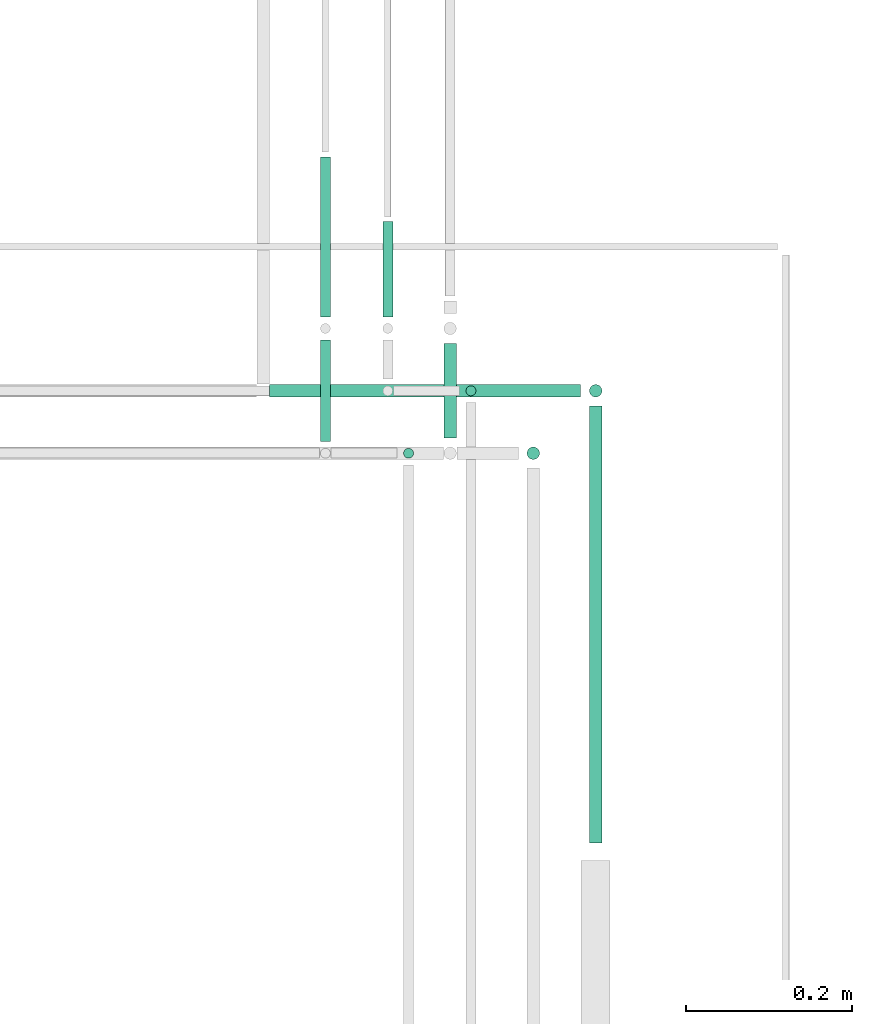
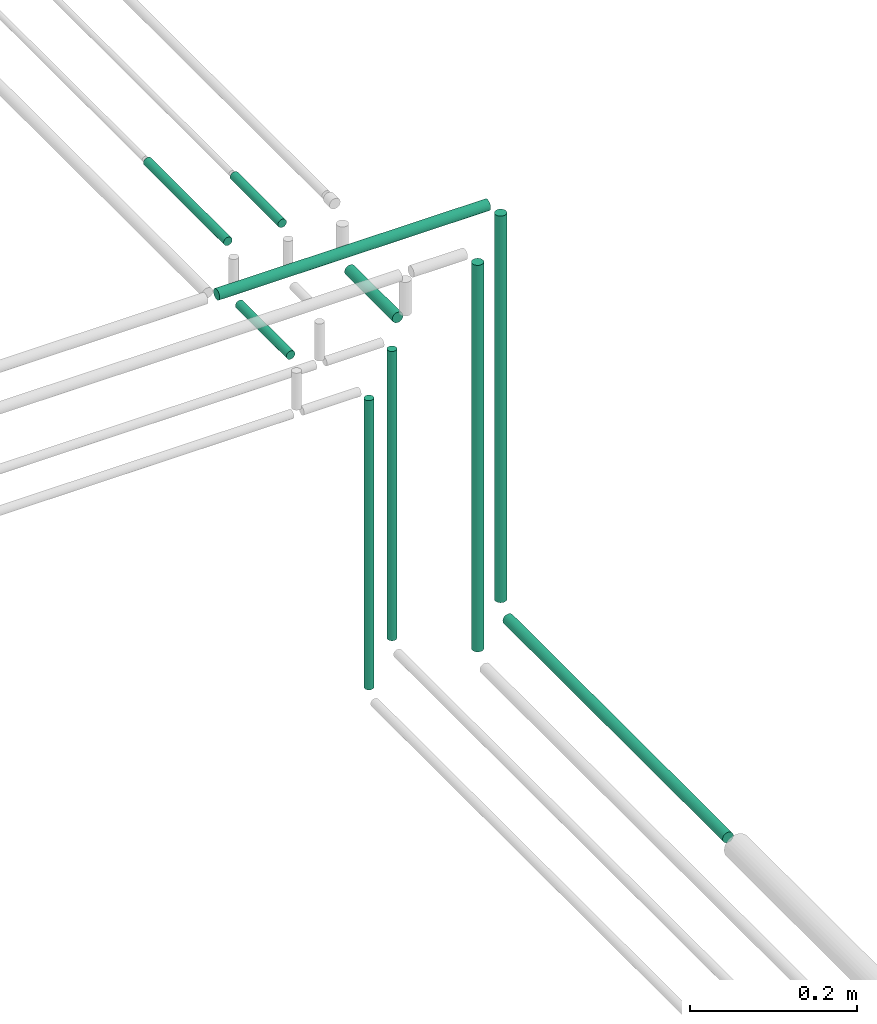
# One storey, part 246 of 331: 10 flow segments.
"""IFC2X3 building model written with IfcOpenShell, lengths in millimetres."""

from ifc_helpers import new_model, entity, si_unit, converted_unit, derived_unit, direction, frame, frame_2d, origin, origin_2d_with_axis, place, context, subcontext, project, spatial, circle, extrude, type_object, element, save


model = new_model("IFC2X3")

# Units and contexts
model_context = context("Model", 3, precision=0.01, world=origin(), true_north=direction((6.12303176911189e-17, 1.0)))
body_context = subcontext(model_context, "Body", "Model", "MODEL_VIEW")
ifc_project = project(units=[si_unit("LENGTHUNIT", "METRE", prefix="MILLI"), si_unit("AREAUNIT", "SQUARE_METRE"), si_unit("VOLUMEUNIT", "CUBIC_METRE"), converted_unit("PLANEANGLEUNIT", "DEGREE", entity("IfcRatioMeasure", 0.0174532925199433), si_unit("PLANEANGLEUNIT", "RADIAN"), dimensions=[0, 0, 0, 0, 0, 0, 0]), si_unit("MASSUNIT", "GRAM", prefix="KILO"), derived_unit("MASSDENSITYUNIT", [(si_unit("MASSUNIT", "GRAM", prefix="KILO"), 1), (si_unit("LENGTHUNIT", "METRE"), -3)]), derived_unit("MOMENTOFINERTIAUNIT", [(si_unit("LENGTHUNIT", "METRE"), 4)]), si_unit("TIMEUNIT", "SECOND"), si_unit("FREQUENCYUNIT", "HERTZ"), si_unit("THERMODYNAMICTEMPERATUREUNIT", "DEGREE_CELSIUS"), derived_unit("THERMALTRANSMITTANCEUNIT", [(si_unit("MASSUNIT", "GRAM", prefix="KILO"), 1), (si_unit("THERMODYNAMICTEMPERATUREUNIT", "KELVIN"), -1), (si_unit("TIMEUNIT", "SECOND"), -3)]), derived_unit("VOLUMETRICFLOWRATEUNIT", [(si_unit("LENGTHUNIT", "METRE"), 3), (si_unit("TIMEUNIT", "SECOND"), -1)]), derived_unit("MASSFLOWRATEUNIT", [(si_unit("MASSUNIT", "GRAM", prefix="KILO"), 1), (si_unit("TIMEUNIT", "SECOND"), -1)]), derived_unit("ROTATIONALFREQUENCYUNIT", [(si_unit("TIMEUNIT", "SECOND"), -1)]), si_unit("ELECTRICCURRENTUNIT", "AMPERE"), si_unit("ELECTRICVOLTAGEUNIT", "VOLT"), si_unit("POWERUNIT", "WATT"), si_unit("FORCEUNIT", "NEWTON", prefix="KILO"), si_unit("ILLUMINANCEUNIT", "LUX"), si_unit("LUMINOUSFLUXUNIT", "LUMEN"), si_unit("LUMINOUSINTENSITYUNIT", "CANDELA"), derived_unit("USERDEFINED", [(si_unit("MASSUNIT", "GRAM", prefix="KILO"), -1), (si_unit("LENGTHUNIT", "METRE"), -2), (si_unit("TIMEUNIT", "SECOND"), 3), (si_unit("LUMINOUSFLUXUNIT", "LUMEN"), 1)]), derived_unit("LINEARVELOCITYUNIT", [(si_unit("LENGTHUNIT", "METRE"), 1), (si_unit("TIMEUNIT", "SECOND"), -1)]), si_unit("PRESSUREUNIT", "PASCAL"), derived_unit("USERDEFINED", [(si_unit("LENGTHUNIT", "METRE"), -2), (si_unit("MASSUNIT", "GRAM", prefix="KILO"), 1), (si_unit("TIMEUNIT", "SECOND"), -2)]), derived_unit("LINEARFORCEUNIT", [(si_unit("MASSUNIT", "GRAM", prefix="KILO"), 1), (si_unit("LENGTHUNIT", "METRE"), 1), (si_unit("TIMEUNIT", "SECOND"), -2), (si_unit("LENGTHUNIT", "METRE"), -1)]), derived_unit("PLANARFORCEUNIT", [(si_unit("MASSUNIT", "GRAM", prefix="KILO"), 1), (si_unit("LENGTHUNIT", "METRE"), 1), (si_unit("TIMEUNIT", "SECOND"), -2), (si_unit("LENGTHUNIT", "METRE"), -2)])], contexts=[model_context])

# Site, building, storey
site_placement = place(None, frame((0.0, -0.00077364408347762, 0.0)))
site = spatial("IfcSite", under=ifc_project, at=site_placement, CompositionType="ELEMENT")
building_placement = place(site_placement, origin())
building = spatial("IfcBuilding", under=site, at=building_placement, CompositionType="ELEMENT")
storey_placement = place(building_placement, origin())
storey = spatial("IfcBuildingStorey", under=building, at=storey_placement, CompositionType="ELEMENT", Elevation=0.0)

# Flow segments
pipe_segment_type = type_object("IfcPipeSegmentType", PredefinedType="NOTDEFINED")
flow_segment_1_placement = place(storey_placement, frame((61987.0947663298, 15581.5750474038, 18440.9047277641)))
element("IfcFlowSegment", 1, at=flow_segment_1_placement, inside=storey, type_object=pipe_segment_type, context=body_context, shape_type="SweptSolid", body=[
    extrude(circle(Radius=7.5, at=frame_2d((0.0, -2.16573425859679e-12), x_axis=(1.0, 0.0))), frame((9.09527223591419, 0.0, 9.09527223591419), z_axis=(0.0, 1.0, 0.0), x_axis=(1.0, 0.0, 0.0)), (0.0, 0.0, 1.0), 525.534919564053),
])
flow_segment_2_placement = place(building_placement, frame((61987.0947663298, 16116.0146947319, 18468.0)))
element("IfcFlowSegment", 2, at=flow_segment_2_placement, inside=storey, type_object=pipe_segment_type, context=body_context, shape_type="SweptSolid", body=[
    extrude(circle(Radius=7.5, at=frame_2d((0.0, -2.16573425859679e-12), x_axis=(1.0, 0.0))), frame((9.09527223591419, 9.09527223591419, 0.0), z_axis=(0.0, 0.0, 1.0), x_axis=(-1.0, 0.0, 0.0)), (0.0, 0.0, 1.0), 564.000000000082),
])
flow_segment_3_placement = place(building_placement, frame((61604.1900385657, 16116.0146947319, 19040.9047277642)))
element("IfcFlowSegment", 3, at=flow_segment_3_placement, inside=storey, type_object=pipe_segment_type, context=body_context, shape_type="SweptSolid", body=[
    extrude(circle(Radius=7.5, at=frame_2d((-4.33146851719357e-12, 0.0), x_axis=(1.0, 0.0))), frame((0.0, 9.09527223592069, 9.09527223591636), z_axis=(1.0, 0.0, 0.0), x_axis=(0.0, 1.0, 0.0)), (0.0, 0.0, 1.0), 373.999999999993),
])
flow_segment_4_placement = place(building_placement, frame((61812.0947663298, 16068.1099669678, 18965.9047277641)))
element("IfcFlowSegment", 4, at=flow_segment_4_placement, inside=storey, type_object=pipe_segment_type, context=body_context, shape_type="SweptSolid", body=[
    extrude(circle(Radius=7.5, at=frame_2d((0.0, -2.16573425859679e-12), x_axis=(1.0, 0.0))), frame((9.09527223591419, 0.0, 9.09527223591853), z_axis=(0.0, 1.0, 0.0), x_axis=(-1.0, 0.0, 0.0)), (0.0, 0.0, 1.0), 114.000000000013),
])
flow_segment_5_placement = place(building_placement, frame((61912.0947663298, 16041.0146947319, 18468.0)))
element("IfcFlowSegment", 5, at=flow_segment_5_placement, inside=storey, type_object=pipe_segment_type, context=body_context, shape_type="SweptSolid", body=[
    extrude(circle(Radius=7.5, at=origin_2d_with_axis()), frame((9.09527223591419, 9.09527223591636, 0.0), z_axis=(0.0, 0.0, 1.0), x_axis=(-1.0, 0.0, 0.0)), (0.0, 0.0, 1.0), 564.000000000013),
])
flow_segment_6_placement = place(building_placement, frame((61838.5947663298, 16117.5146947319, 18464.0)))
element("IfcFlowSegment", 6, at=flow_segment_6_placement, inside=storey, type_object=pipe_segment_type, context=body_context, shape_type="SweptSolid", body=[
    extrude(circle(Radius=6.0, at=frame_2d((0.0, -2.16573425859679e-12), x_axis=(1.0, 0.0))), frame((7.59527223591454, 7.59527223591454, 0.0), z_axis=(0.0, 0.0, 1.0), x_axis=(-1.0, 0.0, 0.0)), (0.0, 0.0, 1.0), 421.999999999993),
])
flow_segment_7_placement = place(building_placement, frame((61763.5947663298, 16042.5146947319, 18464.0)))
element("IfcFlowSegment", 7, at=flow_segment_7_placement, inside=storey, type_object=pipe_segment_type, context=body_context, shape_type="SweptSolid", body=[
    extrude(circle(Radius=6.0, at=frame_2d((0.0, 2.16573425859679e-12), x_axis=(1.0, 0.0))), frame((7.59527223591454, 7.59527223591887, 0.0), z_axis=(0.0, 0.0, 1.0), x_axis=(-1.0, 0.0, 0.0)), (0.0, 0.0, 1.0), 422.000000000012),
])
flow_segment_8_placement = place(storey_placement, frame((61663.5947663298, 16064.1099669678, 18967.4047277641)))
element("IfcFlowSegment", 8, at=flow_segment_8_placement, inside=storey, type_object=pipe_segment_type, context=body_context, shape_type="SweptSolid", body=[
    extrude(circle(Radius=6.0, at=frame_2d((0.0, -2.16573425859679e-12), x_axis=(1.0, 0.0))), frame((7.59527223591454, 0.0, 7.59527223591887), z_axis=(0.0, 1.0, 0.0), x_axis=(-1.0, 0.0, 0.0)), (0.0, 0.0, 1.0), 122.000000000013),
])
flow_segment_9_placement = place(storey_placement, frame((61663.5947663298, 16214.1099669678, 19042.4047277642)))
element("IfcFlowSegment", 9, at=flow_segment_9_placement, inside=storey, type_object=pipe_segment_type, context=body_context, shape_type="SweptSolid", body=[
    extrude(circle(Radius=6.0, at=frame_2d((0.0, -2.16573425859679e-12), x_axis=(1.0, 0.0))), frame((7.5952722359232, 0.0, 7.59527223591454), z_axis=(0.0, 1.0, 0.0), x_axis=(1.0, 0.0, 0.0)), (0.0, 0.0, 1.0), 192.020106336262),
])
flow_segment_10_placement = place(storey_placement, frame((61738.5947663298, 16214.1099669678, 19042.4047277642)))
element("IfcFlowSegment", 10, at=flow_segment_10_placement, inside=storey, type_object=pipe_segment_type, context=body_context, shape_type="SweptSolid", body=[
    extrude(circle(Radius=6.0, at=frame_2d((0.0, -2.16573425859679e-12), x_axis=(1.0, 0.0))), frame((7.5952722359232, 0.0, 7.59527223591454), z_axis=(0.0, 1.0, 0.0), x_axis=(1.0, 0.0, 0.0)), (0.0, 0.0, 1.0), 114.342211826453),
])

save(model, "model.ifc")
